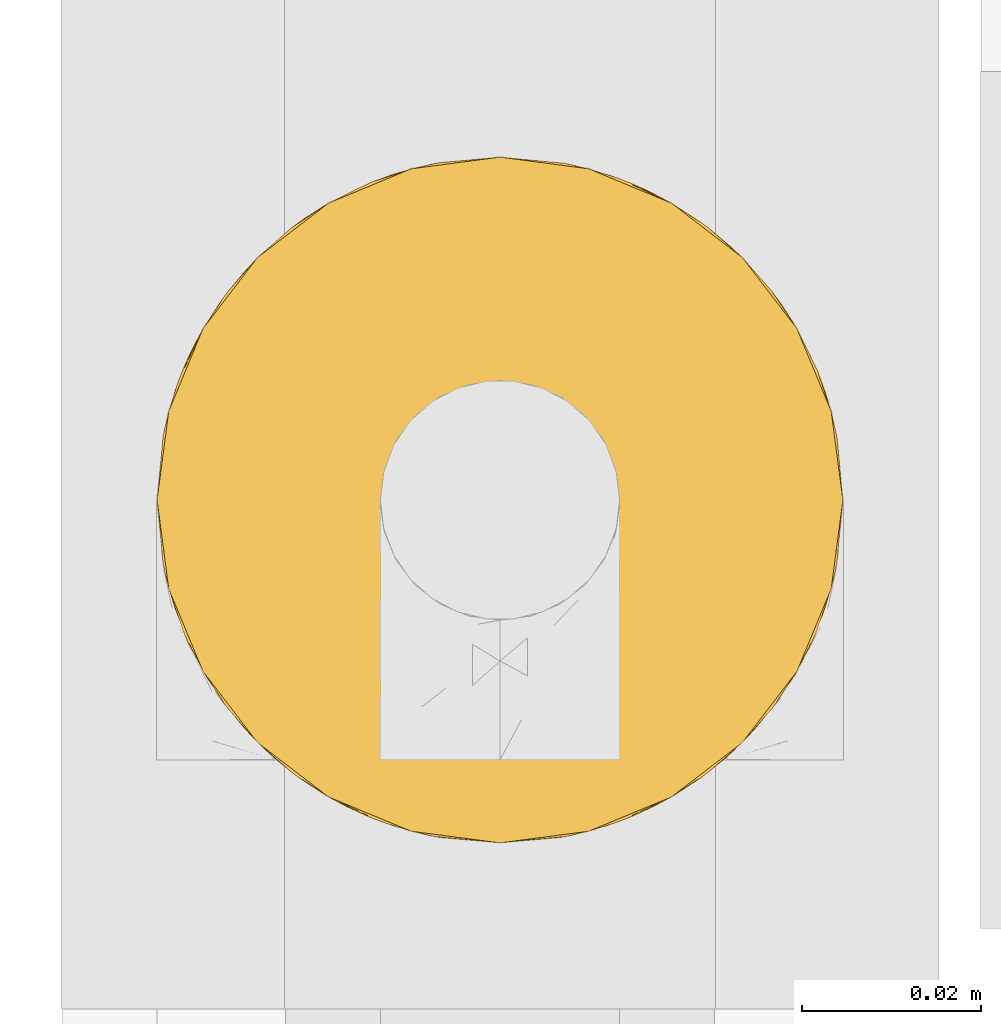
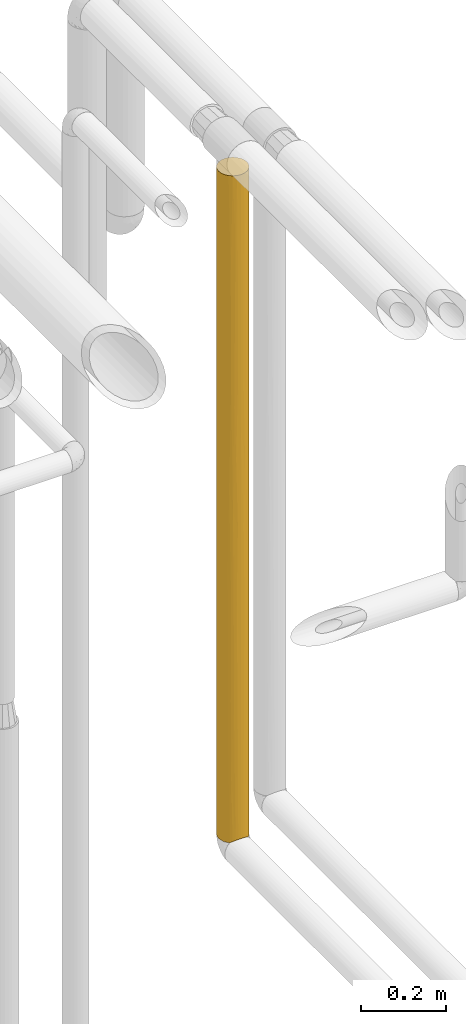
# One storey, part 51 of 827: 1 covering.
"""IFC2X3 building model written with IfcOpenShell, lengths in millimetres."""

from ifc_helpers import new_model, entity, si_unit, converted_unit, derived_unit, direction, frame, origin, place, context, subcontext, project, spatial, faceted_brep, element, save


model = new_model("IFC2X3")

# Units and contexts
model_context = context("Model", 3, precision=0.01, world=origin(), true_north=direction((6.12303176911189e-17, 1.0)))
body_context = subcontext(model_context, "Body", "Model", "MODEL_VIEW")
ifc_project = project(units=[si_unit("LENGTHUNIT", "METRE", prefix="MILLI"), si_unit("AREAUNIT", "SQUARE_METRE"), si_unit("VOLUMEUNIT", "CUBIC_METRE"), converted_unit("PLANEANGLEUNIT", "DEGREE", entity("IfcRatioMeasure", 0.0174532925199433), si_unit("PLANEANGLEUNIT", "RADIAN"), dimensions=[0, 0, 0, 0, 0, 0, 0]), si_unit("MASSUNIT", "GRAM", prefix="KILO"), derived_unit("MASSDENSITYUNIT", [(si_unit("MASSUNIT", "GRAM", prefix="KILO"), 1), (si_unit("LENGTHUNIT", "METRE"), -3)]), derived_unit("MOMENTOFINERTIAUNIT", [(si_unit("LENGTHUNIT", "METRE"), 4)]), si_unit("TIMEUNIT", "SECOND"), si_unit("FREQUENCYUNIT", "HERTZ"), si_unit("THERMODYNAMICTEMPERATUREUNIT", "DEGREE_CELSIUS"), derived_unit("THERMALTRANSMITTANCEUNIT", [(si_unit("MASSUNIT", "GRAM", prefix="KILO"), 1), (si_unit("THERMODYNAMICTEMPERATUREUNIT", "KELVIN"), -1), (si_unit("TIMEUNIT", "SECOND"), -3)]), derived_unit("VOLUMETRICFLOWRATEUNIT", [(si_unit("LENGTHUNIT", "METRE"), 3), (si_unit("TIMEUNIT", "SECOND"), -1)]), derived_unit("MASSFLOWRATEUNIT", [(si_unit("MASSUNIT", "GRAM", prefix="KILO"), 1), (si_unit("TIMEUNIT", "SECOND"), -1)]), derived_unit("ROTATIONALFREQUENCYUNIT", [(si_unit("TIMEUNIT", "SECOND"), -1)]), si_unit("ELECTRICCURRENTUNIT", "AMPERE"), si_unit("ELECTRICVOLTAGEUNIT", "VOLT"), si_unit("POWERUNIT", "WATT"), si_unit("FORCEUNIT", "NEWTON", prefix="KILO"), si_unit("ILLUMINANCEUNIT", "LUX"), si_unit("LUMINOUSFLUXUNIT", "LUMEN"), si_unit("LUMINOUSINTENSITYUNIT", "CANDELA"), derived_unit("USERDEFINED", [(si_unit("MASSUNIT", "GRAM", prefix="KILO"), -1), (si_unit("LENGTHUNIT", "METRE"), -2), (si_unit("TIMEUNIT", "SECOND"), 3), (si_unit("LUMINOUSFLUXUNIT", "LUMEN"), 1)]), derived_unit("LINEARVELOCITYUNIT", [(si_unit("LENGTHUNIT", "METRE"), 1), (si_unit("TIMEUNIT", "SECOND"), -1)]), si_unit("PRESSUREUNIT", "PASCAL"), derived_unit("USERDEFINED", [(si_unit("LENGTHUNIT", "METRE"), -2), (si_unit("MASSUNIT", "GRAM", prefix="KILO"), 1), (si_unit("TIMEUNIT", "SECOND"), -2)]), derived_unit("LINEARFORCEUNIT", [(si_unit("MASSUNIT", "GRAM", prefix="KILO"), 1), (si_unit("LENGTHUNIT", "METRE"), 1), (si_unit("TIMEUNIT", "SECOND"), -2), (si_unit("LENGTHUNIT", "METRE"), -1)]), derived_unit("PLANARFORCEUNIT", [(si_unit("MASSUNIT", "GRAM", prefix="KILO"), 1), (si_unit("LENGTHUNIT", "METRE"), 1), (si_unit("TIMEUNIT", "SECOND"), -2), (si_unit("LENGTHUNIT", "METRE"), -2)])], contexts=[model_context])

# Site, building, storey
site_placement = place(None, origin())
site = spatial("IfcSite", under=ifc_project, at=site_placement, CompositionType="ELEMENT")
building_placement = place(site_placement, origin())
building = spatial("IfcBuilding", under=site, at=building_placement, CompositionType="ELEMENT")
storey_placement = place(building_placement, frame((0.0, 0.0, 28200.0)))
storey = spatial("IfcBuildingStorey", under=building, at=storey_placement, Name="08", CompositionType="ELEMENT", Elevation=28200.0)

# Covering
covering_placement = place(storey_placement, frame((61012.64, 17412.84, 1027.51)))
element("IfcCovering", 1, at=covering_placement, inside=storey, Name=":ADSK_", ObjectType=":ADSK_", PredefinedType="INSULATION", context=body_context, shape_type="Brep", body=[
    faceted_brep([(2.48, 31.79, 1.6), (1.6, 40.0, 1.6), (2.9, 49.93, 1.6), (6.74, 59.2, 1.6), (12.84, 67.15, 1.6), (20.8, 73.25, 1.6), (30.06, 77.09, 1.6), (40.0, 78.4, 1.6), (49.93, 77.09, 1.6), (59.2, 73.25, 1.6), (67.15, 67.15, 1.6), (73.25, 59.2, 1.6), (77.09, 49.93, 1.6), (78.4, 40.0, 1.6), (77.51, 31.79, 1.6), (74.9, 23.98, 1.6), (70.68, 16.91, 1.6), (65.05, 10.9, 1.6), (14.94, 10.9, 1.6), (9.31, 16.91, 1.6), (5.09, 23.98, 1.6), (6.74, 20.8, 1915.23), (12.84, 12.84, 1915.23), (20.8, 6.74, 1915.23), (30.06, 2.9, 1915.23), (40.0, 1.6, 1915.23), (49.93, 2.9, 1915.23), (59.2, 6.74, 1915.23), (67.15, 12.84, 1915.23), (73.25, 20.8, 1915.23), (77.09, 30.06, 1915.23), (78.4, 40.0, 1915.23), (77.09, 49.93, 1915.23), (73.25, 59.2, 1915.23), (67.15, 67.15, 1915.23), (59.2, 73.25, 1915.23), (49.93, 77.09, 1915.23), (40.0, 78.4, 1915.23), (30.06, 77.09, 1915.23), (20.8, 73.25, 1915.23), (12.84, 67.15, 1915.23), (6.74, 59.2, 1915.23), (2.9, 49.93, 1915.23), (1.6, 40.0, 1915.23), (2.9, 30.06, 1915.23), (70.46, 16.62, 1662.64), (48.24, 2.49, 335.45), (50.46, 3.05, 688.07), (40.0, 1.6, 443.64), (40.0, 1.6, 1698.86), (47.32, 2.3, 1590.67), (70.46, 16.62, 1284.53), (63.37, 9.53, 1633.37), (62.5, 8.88, 1312.77), (77.73, 32.9, 1590.67), (75.47, 25.3, 1549.98), (78.4, 40.0, 217.97), (74.9, 23.99, 1201.67), (77.12, 30.18, 1020.94), (77.45, 31.51, 1328.64), (78.4, 40.0, 867.09), (78.4, 40.0, 1174.79), (77.14, 30.25, 616.82), (76.18, 27.14, 818.45), (72.61, 19.72, 691.53), (76.41, 27.82, 287.23), (72.98, 20.33, 218.66), (72.98, 20.33, 485.18), (53.36, 4.0, 8.5), (59.51, 6.92, 5.57), (62.48, 8.86, 194.06), (63.21, 9.41, 406.86), (68.03, 13.75, 287.24), (67.73, 13.43, 544.14), (53.24, 3.95, 1719.84), (40.0, 1.6, 1482.49), (47.27, 2.29, 1330.96), (46.78, 2.2, 10.29), (68.76, 14.56, 783.55), (62.77, 9.08, 717.19), (40.0, 1.6, 227.27), (40.0, 1.6, 10.9), (47.85, 2.41, 904.36), (40.0, 1.6, 1179.44), (40.0, 1.6, 876.39), (40.0, 1.6, 660.01), (56.68, 5.41, 384.99), (78.4, 40.0, 1482.49), (78.4, 40.0, 434.34), (57.11, 5.62, 606.06), (66.14, 11.87, 1017.09), (58.91, 6.58, 949.46), (54.69, 4.52, 1504.92), (78.4, 40.0, 650.71), (78.4, 40.0, 1698.86), (70.87, 17.17, 1073.01), (55.88, 5.04, 1285.32), (73.14, 20.6, 896.78), (51.89, 3.48, 1099.87), (32.67, 2.3, 1590.67), (26.75, 3.95, 1719.84), (25.3, 4.52, 1504.92), (21.08, 6.58, 949.46), (17.49, 8.88, 1312.77), (13.85, 11.87, 1017.09), (22.88, 5.62, 606.06), (29.53, 3.05, 688.07), (16.62, 9.53, 1633.37), (9.53, 16.62, 1662.64), (9.53, 16.62, 1284.53), (26.63, 4.0, 8.5), (23.31, 5.41, 384.99), (17.51, 8.86, 194.06), (7.01, 20.33, 218.66), (31.75, 2.49, 335.45), (33.21, 2.2, 10.29), (16.78, 9.41, 406.86), (4.52, 25.3, 1549.98), (2.54, 31.51, 1328.64), (1.6, 40.0, 1482.49), (1.6, 40.0, 1266.11), (1.6, 40.0, 1174.79), (3.58, 27.82, 287.23), (1.6, 40.0, 217.97), (32.14, 2.41, 904.36), (2.87, 30.18, 1020.94), (1.6, 40.0, 1049.74), (1.6, 40.0, 867.09), (11.23, 14.56, 783.55), (9.12, 17.17, 1073.01), (11.96, 13.75, 287.24), (12.26, 13.43, 544.14), (7.01, 20.33, 485.18), (2.85, 30.25, 616.82), (1.6, 40.0, 434.34), (2.26, 32.9, 1590.67), (1.6, 40.0, 1698.86), (32.72, 2.29, 1330.96), (20.48, 6.92, 5.57), (17.22, 9.08, 717.19), (7.38, 19.72, 691.53), (2.29, 32.75, 819.22), (1.6, 40.0, 650.71), (5.09, 23.99, 1201.67), (24.11, 5.04, 1285.32), (6.85, 20.6, 896.78), (28.1, 3.48, 1099.87), (1.6, 40.0, 742.04), (25.3, 75.47, 1561.93), (9.53, 63.37, 1633.37), (18.11, 71.55, 779.98), (20.18, 72.89, 1056.31), (27.86, 76.43, 833.77), (3.95, 53.24, 196.99), (2.3, 47.32, 326.15), (3.64, 52.36, 1138.34), (2.54, 48.44, 881.68), (3.95, 53.24, 1719.84), (2.3, 47.32, 1590.67), (33.12, 77.77, 563.24), (40.0, 78.4, 434.34), (32.71, 77.7, 326.15), (5.71, 57.29, 926.33), (16.62, 70.46, 1662.64), (16.62, 70.46, 1313.18), (16.62, 70.46, 325.87), (8.88, 62.49, 1313.66), (4.52, 54.69, 1504.92), (9.53, 63.37, 260.79), (2.27, 47.15, 1337.83), (6.71, 59.14, 1132.37), (40.0, 78.4, 217.97), (25.3, 75.47, 531.31), (25.3, 75.47, 246.65), (40.0, 78.4, 1698.86), (33.06, 77.76, 1349.74), (25.78, 75.67, 1343.75), (9.53, 63.37, 765.89), (12.45, 66.75, 1048.1), (11.66, 65.91, 513.34), (32.93, 77.74, 1590.67), (40.0, 78.4, 1482.49), (40.0, 78.4, 1174.79), (28.77, 76.72, 1145.09), (17.48, 71.1, 552.41), (40.0, 78.4, 867.09), (4.52, 54.69, 411.91), (5.22, 56.29, 666.17), (2.45, 48.07, 599.6), (40.0, 78.4, 742.04), (40.0, 78.4, 650.71), (40.0, 78.4, 1049.74), (40.0, 78.4, 1266.11), (75.47, 54.69, 1561.93), (63.37, 70.46, 1633.37), (62.49, 71.11, 1313.66), (54.69, 75.47, 1504.92), (59.14, 73.28, 1132.37), (47.15, 77.72, 1337.83), (47.32, 77.69, 1590.67), (53.24, 76.04, 1719.84), (77.7, 47.28, 326.15), (77.77, 46.88, 563.24), (53.24, 76.04, 196.99), (47.32, 77.69, 326.15), (75.47, 54.69, 246.65), (52.36, 76.35, 1138.34), (57.29, 74.28, 926.33), (48.44, 77.46, 881.68), (70.46, 63.37, 325.87), (63.37, 70.46, 260.79), (70.46, 63.37, 1662.64), (70.46, 63.37, 1313.18), (75.47, 54.69, 531.31), (77.76, 46.94, 1349.74), (75.67, 54.21, 1343.75), (71.55, 61.88, 779.98), (63.37, 70.46, 765.89), (66.75, 67.54, 1048.1), (72.89, 59.81, 1056.31), (76.43, 52.13, 833.77), (77.74, 47.06, 1590.67), (65.91, 68.33, 513.34), (76.72, 51.22, 1145.09), (71.1, 62.51, 552.41), (54.69, 75.47, 411.91), (56.29, 74.77, 666.17), (48.07, 77.54, 599.6)], [[[0, 1, 2, 3, 4, 5, 6, 7, 8, 9, 10, 11, 12, 13, 14, 15, 16, 17, 18, 19, 20]], [[21, 22, 23, 24, 25, 26, 27, 28, 29, 30, 31, 32, 33, 34, 35, 36, 37, 38, 39, 40, 41, 42, 43, 44]], [[29, 28, 45]], [[46, 47, 48]], [[49, 50, 26]], [[51, 52, 53]], [[54, 30, 55]], [[14, 13, 56]], [[57, 58, 59]], [[52, 45, 28]], [[58, 60, 61]], [[62, 63, 64]], [[65, 66, 15]], [[67, 65, 62]], [[68, 69, 70]], [[65, 15, 14]], [[71, 72, 73]], [[26, 50, 74]], [[75, 76, 50]], [[77, 68, 46]], [[29, 55, 30]], [[71, 70, 72]], [[75, 50, 49]], [[16, 66, 72]], [[52, 27, 74]], [[16, 72, 17]], [[66, 67, 72]], [[73, 78, 79]], [[80, 81, 77]], [[82, 83, 84, 85]], [[27, 52, 28]], [[85, 48, 47]], [[46, 68, 86]], [[48, 80, 46]], [[87, 54, 59]], [[73, 72, 67]], [[70, 69, 17]], [[65, 56, 88]], [[62, 65, 88]], [[77, 46, 80]], [[46, 86, 47]], [[86, 89, 47]], [[51, 53, 90]], [[47, 89, 91]], [[50, 76, 92]], [[53, 52, 92]], [[45, 51, 55]], [[62, 88, 93, 60]], [[30, 54, 94]], [[60, 58, 63]], [[95, 51, 90]], [[92, 96, 53]], [[14, 56, 65]], [[90, 91, 79]], [[51, 45, 52]], [[55, 29, 45]], [[53, 96, 91]], [[90, 79, 78]], [[57, 97, 58]], [[59, 61, 87]], [[63, 58, 97]], [[57, 55, 51]], [[58, 61, 59]], [[26, 25, 49]], [[83, 76, 75]], [[50, 92, 74]], [[83, 98, 76]], [[76, 98, 96]], [[52, 74, 92]], [[27, 26, 74]], [[94, 54, 87]], [[94, 31, 30]], [[59, 54, 55]], [[55, 57, 59]], [[57, 51, 95]], [[78, 64, 97]], [[79, 89, 71]], [[64, 73, 67]], [[78, 97, 95]], [[79, 71, 73]], [[86, 68, 70]], [[72, 70, 17]], [[86, 70, 71]], [[73, 64, 78]], [[62, 64, 67]], [[53, 91, 90]], [[91, 98, 82]], [[15, 66, 16]], [[67, 66, 65]], [[82, 85, 47]], [[71, 89, 86]], [[91, 89, 79]], [[91, 82, 47]], [[83, 82, 98]], [[76, 96, 92]], [[91, 96, 98]], [[78, 95, 90]], [[57, 95, 97]], [[64, 63, 97]], [[60, 63, 62]], [[99, 100, 101]], [[102, 103, 104]], [[49, 25, 24]], [[102, 105, 106]], [[107, 23, 22]], [[107, 22, 108]], [[109, 107, 108]], [[110, 111, 112]], [[113, 20, 19]], [[80, 114, 115]], [[116, 112, 111]], [[117, 21, 44]], [[118, 119, 120, 121]], [[122, 123, 0]], [[80, 48, 114]], [[20, 122, 0]], [[124, 102, 106]], [[125, 121, 126, 127]], [[128, 104, 129]], [[113, 19, 130]], [[130, 131, 132]], [[132, 122, 113]], [[122, 133, 134]], [[119, 135, 136]], [[24, 100, 99]], [[137, 83, 75]], [[101, 100, 107]], [[18, 130, 19]], [[110, 115, 114]], [[114, 106, 111]], [[44, 136, 135]], [[118, 135, 119]], [[112, 18, 138]], [[116, 139, 131]], [[133, 122, 132]], [[0, 123, 1]], [[115, 81, 80]], [[106, 48, 85]], [[114, 111, 110]], [[106, 85, 124]], [[105, 111, 106]], [[75, 99, 137]], [[101, 107, 103]], [[22, 21, 108]], [[103, 107, 109]], [[133, 132, 140]], [[141, 142, 133]], [[131, 128, 140]], [[143, 117, 118]], [[104, 103, 109]], [[134, 123, 122]], [[144, 101, 103]], [[21, 117, 108]], [[109, 108, 117]], [[129, 104, 109]], [[102, 104, 139]], [[141, 145, 125]], [[141, 125, 127]], [[129, 143, 145]], [[121, 125, 118]], [[143, 118, 125]], [[24, 99, 49]], [[75, 49, 99]], [[124, 83, 146]], [[101, 144, 137]], [[101, 137, 99]], [[146, 83, 137]], [[24, 23, 100]], [[107, 100, 23]], [[44, 43, 136]], [[118, 117, 135]], [[44, 135, 117]], [[145, 143, 125]], [[117, 143, 109]], [[116, 131, 130]], [[128, 131, 139]], [[104, 128, 139]], [[140, 128, 145]], [[130, 18, 112]], [[116, 111, 105]], [[112, 138, 110]], [[130, 112, 116]], [[133, 140, 145]], [[131, 140, 132]], [[102, 139, 105]], [[102, 146, 144]], [[132, 113, 130]], [[20, 113, 122]], [[48, 106, 114]], [[84, 83, 124, 85]], [[116, 105, 139]], [[102, 124, 146]], [[102, 144, 103]], [[142, 134, 133]], [[137, 144, 146]], [[143, 129, 109]], [[128, 129, 145]], [[141, 127, 147, 142]], [[145, 141, 133]], [[148, 39, 38]], [[149, 41, 40]], [[150, 151, 152]], [[153, 2, 154]], [[42, 136, 43]], [[126, 155, 156]], [[42, 157, 158]], [[159, 160, 161]], [[156, 155, 162]], [[149, 163, 164]], [[165, 5, 4]], [[149, 166, 167]], [[165, 4, 168]], [[158, 157, 167]], [[169, 119, 158]], [[167, 166, 170]], [[161, 160, 171]], [[154, 2, 123]], [[167, 157, 149]], [[40, 163, 149]], [[165, 172, 173]], [[38, 37, 174]], [[6, 171, 7]], [[148, 175, 176]], [[150, 177, 178]], [[134, 154, 123]], [[6, 5, 173]], [[179, 165, 168]], [[180, 174, 181]], [[175, 182, 183]], [[4, 3, 168]], [[179, 150, 184]], [[180, 175, 148]], [[185, 159, 152]], [[40, 39, 163]], [[166, 149, 164]], [[153, 168, 3]], [[186, 187, 179]], [[164, 178, 166]], [[169, 126, 121, 120, 119]], [[170, 178, 162]], [[188, 154, 134]], [[188, 186, 154]], [[39, 148, 163]], [[164, 163, 148]], [[165, 173, 5]], [[161, 6, 173]], [[178, 151, 150]], [[178, 177, 162]], [[178, 164, 151]], [[179, 184, 165]], [[172, 159, 161]], [[6, 161, 171]], [[172, 161, 173]], [[152, 159, 172]], [[159, 185, 189, 190, 160]], [[150, 152, 172]], [[185, 152, 183]], [[176, 151, 164]], [[152, 151, 183]], [[186, 179, 168]], [[150, 179, 177]], [[180, 181, 175]], [[174, 180, 38]], [[38, 180, 148]], [[183, 182, 191, 185]], [[175, 181, 192, 182]], [[175, 183, 176]], [[151, 176, 183]], [[164, 148, 176]], [[42, 158, 136]], [[119, 136, 158]], [[169, 167, 155]], [[167, 169, 158]], [[126, 169, 155]], [[42, 41, 157]], [[149, 157, 41]], [[2, 1, 123]], [[188, 134, 142, 147]], [[154, 186, 153]], [[156, 188, 147]], [[187, 186, 188]], [[156, 147, 127, 126]], [[187, 162, 177]], [[156, 187, 188]], [[179, 187, 177]], [[156, 162, 187]], [[162, 155, 170]], [[168, 153, 186]], [[3, 2, 153]], [[150, 172, 184]], [[172, 165, 184]], [[167, 170, 155]], [[178, 170, 166]], [[193, 33, 32]], [[194, 195, 196]], [[194, 35, 34]], [[197, 196, 195]], [[198, 181, 199]], [[199, 200, 196]], [[201, 88, 56]], [[202, 88, 201]], [[203, 8, 204]], [[12, 11, 205]], [[206, 207, 208]], [[191, 206, 208]], [[209, 10, 210]], [[209, 11, 10]], [[36, 200, 199]], [[8, 7, 171]], [[174, 37, 36]], [[196, 200, 194]], [[160, 204, 171]], [[194, 211, 212]], [[34, 211, 194]], [[209, 213, 205]], [[193, 214, 215]], [[36, 199, 174]], [[216, 217, 218]], [[216, 219, 220]], [[87, 221, 94]], [[222, 209, 210]], [[32, 94, 221]], [[214, 61, 223]], [[10, 9, 210]], [[12, 56, 13]], [[222, 216, 224]], [[221, 214, 193]], [[60, 202, 220]], [[34, 33, 211]], [[195, 194, 212]], [[203, 210, 9]], [[225, 226, 222]], [[212, 218, 195]], [[198, 191, 182, 192, 181]], [[197, 218, 207]], [[227, 204, 160]], [[227, 225, 204]], [[33, 193, 211]], [[212, 211, 193]], [[209, 205, 11]], [[201, 12, 205]], [[218, 219, 216]], [[218, 217, 207]], [[218, 212, 219]], [[222, 224, 209]], [[213, 202, 201]], [[12, 201, 56]], [[213, 201, 205]], [[220, 202, 213]], [[202, 60, 93, 88]], [[216, 220, 213]], [[60, 220, 223]], [[215, 219, 212]], [[220, 219, 223]], [[225, 222, 210]], [[216, 222, 217]], [[32, 31, 94]], [[221, 87, 214]], [[32, 221, 193]], [[223, 61, 60]], [[61, 214, 87]], [[214, 223, 215]], [[219, 215, 223]], [[212, 193, 215]], [[174, 199, 181]], [[198, 196, 206]], [[196, 198, 199]], [[191, 198, 206]], [[36, 35, 200]], [[194, 200, 35]], [[227, 160, 190, 189]], [[171, 204, 8]], [[204, 225, 203]], [[208, 227, 189]], [[226, 225, 227]], [[208, 189, 185, 191]], [[226, 207, 217]], [[208, 226, 227]], [[222, 226, 217]], [[208, 207, 226]], [[207, 206, 197]], [[210, 203, 225]], [[9, 8, 203]], [[216, 213, 224]], [[213, 209, 224]], [[196, 197, 206]], [[218, 197, 195]], [[69, 68, 77, 81, 115, 110, 138, 18, 17]]]),
])

save(model, "model.ifc")
